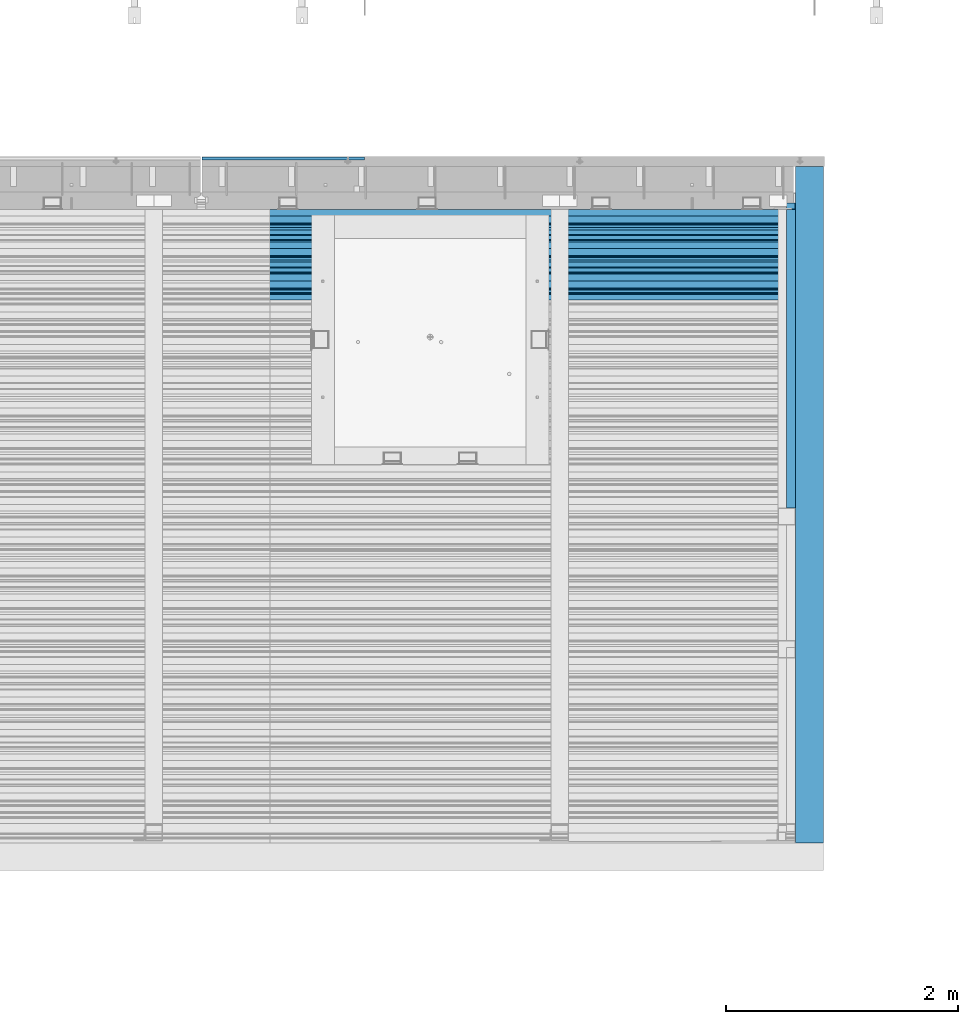
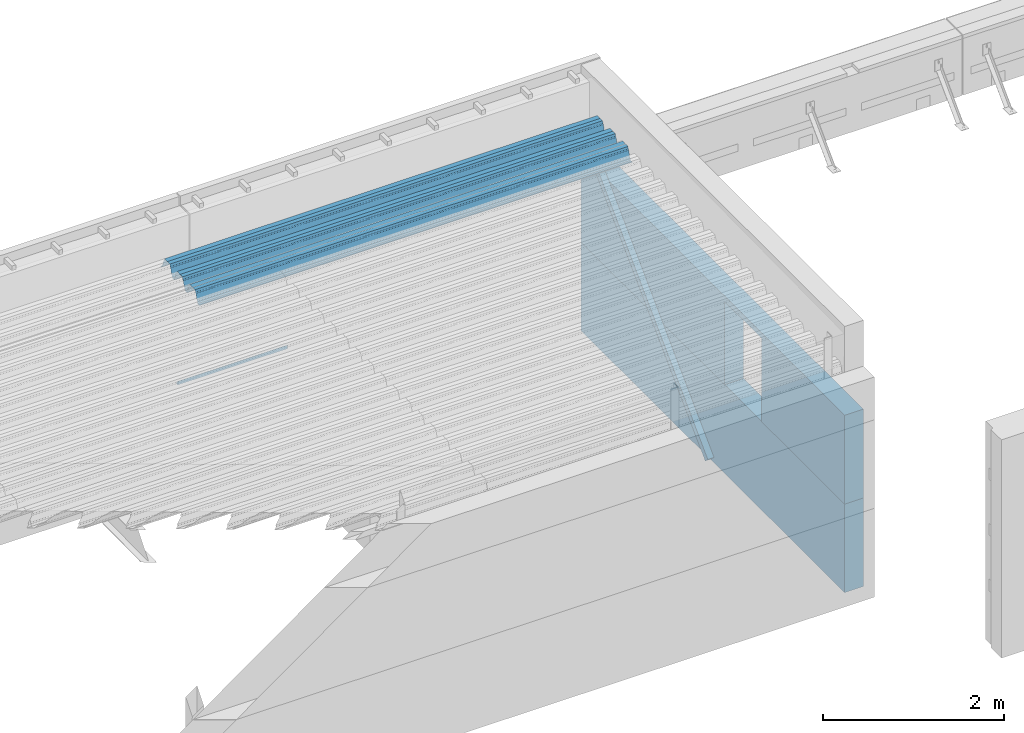
# One storey, part 42 of 153: 4 beams, 1 member, 5 elements without a shape of their own.
"""IFC2X3 building model written with IfcOpenShell, lengths in millimetres."""

from ifc_helpers import new_model, si_unit, frame, origin_with_axes, place, context, subcontext, project, spatial, faceted_brep, material, type_object, element, aggregate, save


model = new_model("IFC2X3")

# Units and contexts
model_context = context("Model", 3, precision=1e-05, world=origin_with_axes())
body_context = subcontext(model_context, "Body", "Model", "MODEL_VIEW")
ifc_project = project(units=[si_unit("LENGTHUNIT", "METRE", prefix="MILLI"), si_unit("AREAUNIT", "SQUARE_METRE"), si_unit("VOLUMEUNIT", "CUBIC_METRE"), si_unit("MASSUNIT", "GRAM", prefix="KILO"), si_unit("TIMEUNIT", "SECOND"), si_unit("PLANEANGLEUNIT", "RADIAN"), si_unit("SOLIDANGLEUNIT", "STERADIAN"), si_unit("THERMODYNAMICTEMPERATUREUNIT", "DEGREE_CELSIUS"), si_unit("LUMINOUSINTENSITYUNIT", "LUMEN")], contexts=[model_context])

# Site, building, storey
site_placement = place(None, origin_with_axes())
site = spatial("IfcSite", under=ifc_project, at=site_placement, CompositionType="ELEMENT")
building_placement = place(site_placement, origin_with_axes())
building = spatial("IfcBuilding", under=site, at=building_placement, CompositionType="ELEMENT")
storey_placement = place(building_placement, origin_with_axes())
storey = spatial("IfcBuildingStorey", under=building, at=storey_placement, Name="8", CompositionType="ELEMENT", Elevation=0.0)

# Assembly, member
assembly_1_placement = place(storey_placement, origin_with_axes())
assembly_1 = element("IfcElementAssembly", 1, at=assembly_1_placement, inside=storey, Name="Steel Assembly", AssemblyPlace="NOTDEFINED", PredefinedType="RIGID_FRAME")
ifc_material_1 = material(Name="STEEL/S355J2")
member_type = type_object("IfcMemberType", Name="80X80X4", PredefinedType="NOTDEFINED")
member_placement = place(assembly_1_placement, frame((21747.0, 17883.2842712475, 102801.715728753), z_axis=(0.0, -0.70710678118662, 0.707106781186475), x_axis=(0.0, 0.70710678118655, 0.707106781186545)))
member = element("IfcMember", 2, at=member_placement, type_object=member_type, material=ifc_material_1, ObjectType="80X80X4", context=body_context, shape_type="Brep", body=[
    faceted_brep([(0.0, 36.0, -36.0), (0.0, -36.0, -36.0), (3641.59992311073, -36.0, -35.9999999999854), (3641.59992311073, 36.0, -35.9999999999854), (0.0, -36.0, 36.0), (3641.59992311073, -36.0, 36.0), (0.0, 36.0, 36.0), (3641.59992311073, 36.0, 36.0), (0.0, 40.0, -40.0), (0.0, 40.0, 40.0), (3641.59992311073, 40.0, 40.0000000000146), (3641.59992311073, 40.0, -40.0), (0.0, -40.0, 40.0), (3641.59992311073, -40.0, 40.0000000000146), (0.0, -40.0, -40.0), (3641.59992311073, -40.0, -40.0)], [[[0, 1, 2, 3]], [[1, 4, 5, 2]], [[4, 6, 7, 5]], [[6, 0, 3, 7]], [[8, 9, 10, 11]], [[9, 12, 13, 10]], [[12, 14, 15, 13]], [[14, 8, 11, 15]], [[13, 15, 11, 10], [5, 7, 3, 2]], [[14, 12, 9, 8], [6, 4, 1, 0]]]),
])
aggregate(assembly_1, [member])

# Assembly, beam
assembly_2_placement = place(storey_placement, origin_with_axes())
assembly_2 = element("IfcElementAssembly", 3, at=assembly_2_placement, inside=storey, AssemblyPlace="NOTDEFINED", PredefinedType="REINFORCEMENT_UNIT")
ifc_material_2 = material(Name="TIMBER/T24")
beam_type_1 = type_object("IfcBeamType", PredefinedType="NOTDEFINED")
beam_1_placement = place(assembly_2_placement, frame((16667.5, 20867.5, 103805.0), z_axis=(0.0, 1.0, 0.0), x_axis=(1.0, 0.0, 0.0)))
beam_1 = element("IfcBeam", 4, at=beam_1_placement, type_object=beam_type_1, material=ifc_material_2, context=body_context, shape_type="Brep", body=[
    faceted_brep([(1400.0, -6.41739461570978e-09, 12.4999999936263), (1.45519152283669e-11, -3.63797880709171e-12, 12.4999999999964), (0.0, -25.0, -12.5), (1400.0, -25.0, -12.5), (0.0, 25.0, -12.5), (0.0, 25.0, 12.5), (1400.0, 25.0, 12.5), (1400.0, 25.0, -12.5)], [[[0, 1, 2, 3]], [[4, 5, 6, 7]], [[7, 6, 0, 3]], [[4, 7, 3, 2]], [[5, 4, 2, 1]], [[6, 5, 1, 0]]]),
])
aggregate(assembly_2, [beam_1])

assembly_3_placement = place(storey_placement, origin_with_axes())
assembly_3 = element("IfcElementAssembly", 5, at=assembly_3_placement, inside=storey, Name="Steel Assembly", AssemblyPlace="NOTDEFINED", PredefinedType="RIGID_FRAME")
beam_type_2 = type_object("IfcBeamType", Name="W", PredefinedType="NOTDEFINED")
beam_2_placement = place(assembly_3_placement, frame((21782.0, 20081.9521353322, 105808.609792946), z_axis=(0.0, -0.0124990270013869, 0.999921884110963), x_axis=(-1.0, 3.00000001838171e-08, 0.0)))
beam_2 = element("IfcBeam", 6, at=beam_2_placement, type_object=beam_type_2, material=ifc_material_1, ObjectType="W", context=body_context, shape_type="Brep", body=[
    faceted_brep([(0.0, -412.839996337891, -77.0100021362159), (0.0, -409.160003662109, -77.0100021362014), (5530.0, -409.160003662109, -77.0100021362014), (5530.0, -412.839996337891, -77.0100021362159), (0.0, -408.070007324222, -73.4800033569045), (5530.0, -408.070007324222, -73.4800033569045), (0.0, -400.339996337894, -48.0600013732619), (5530.0, -400.339996337894, -48.0600013732619), (0.0, -399.459991455082, -46.5600013732619), (5530.0, -399.459991455082, -46.5600013732619), (0.0, -390.329986572269, -36.5499992370314), (5530.0, -390.329986572269, -36.5499992370314), (0.0, -389.19000244141, -34.6300010680861), (5530.0, -389.19000244141, -34.6300010680861), (0.0, -367.820007324222, 35.3400001526024), (5530.0, -367.820007324222, 35.3400001526024), (0.0, -366.989990234379, 36.8499984741502), (5530.0, -366.989990234379, 36.8499984741502), (0.0, -357.809997558597, 46.8600006103807), (5530.0, -357.809997558597, 46.8600006103807), (0.0, -356.720001220707, 48.7700004577782), (5530.0, -356.720001220707, 48.7700004577782), (0.0, -349.309997558594, 73.1500015258935), (5530.0, -349.309997558594, 73.1500015258935), (0.0, -347.850006103516, 75.2300033569481), (5530.0, -347.850006103516, 75.2300033569481), (0.0, -345.470001220707, 76.010002136245), (5530.0, -345.470001220707, 76.010002136245), (0.0, -305.480010986332, 76.010002136245), (5530.0, -305.480010986332, 76.010002136245), (0.0, -304.279998779301, 75.8000030517578), (5530.0, -304.279998779301, 75.8000030517578), (0.0, -291.679992675785, 71.6999969482567), (5530.0, -291.679992675785, 71.6999969482567), (0.0, -290.179992675789, 71.2300033569481), (5530.0, -290.179992675789, 71.2300033569481), (0.0, -288.720001220707, 71.6999969482567), (5530.0, -288.720001220707, 71.6999969482567), (0.0, -276.119995117191, 75.8000030517869), (5530.0, -276.119995117191, 75.8000030517869), (0.0, -274.929992675785, 76.010002136245), (5530.0, -274.929992675785, 76.010002136245), (0.0, -234.94000244141, 76.010002136245), (5530.0, -234.94000244141, 76.010002136245), (0.0, -232.550003051758, 75.2300033569627), (5530.0, -232.550003051758, 75.2300033569627), (0.0, -231.100006103519, 73.1500015258935), (5530.0, -231.100006103519, 73.1500015258935), (0.0, -223.679992675785, 48.7700004577782), (5530.0, -223.679992675785, 48.7700004577782), (0.0, -222.589996337894, 46.8600006103661), (5530.0, -222.589996337894, 46.8600006103661), (0.0, -213.410003662113, 36.8499984741502), (5530.0, -213.410003662113, 36.8499984741502), (0.0, -212.529998779301, 35.3400001526024), (5530.0, -212.529998779301, 35.3400001526024), (0.0, -191.160003662109, -34.6300010681007), (5530.0, -191.160003662109, -34.6300010681007), (0.0, -190.070007324222, -36.5499992370605), (5530.0, -190.070007324222, -36.5499992370605), (0.0, -180.940002441406, -46.560001373291), (5530.0, -180.940002441406, -46.560001373291), (0.0, -180.059997558597, -48.0600013732619), (5530.0, -180.059997558597, -48.0600013732619), (0.0, -172.330001831055, -73.480003356919), (5530.0, -172.330001831055, -73.480003356919), (0.0, -171.240005493168, -77.0100021362159), (5530.0, -171.240005493168, -77.0100021362159), (0.0, -129.330001831062, -77.0100021362014), (5530.0, -129.330001831062, -77.0100021362014), (0.0, -128.300003051761, -73.480003356919), (5530.0, -128.300003051761, -73.480003356919), (0.0, -120.51999664307, -48.0600013732765), (5530.0, -120.51999664307, -48.0600013732765), (0.0, -119.629997253418, -46.5600013732765), (5530.0, -119.629997253418, -46.5600013732765), (0.0, -110.500000000004, -36.5499992370314), (5530.0, -110.500000000004, -36.5499992370314), (0.0, -109.419998168949, -34.6300010680861), (5530.0, -109.419998168949, -34.6300010680861), (0.0, -88.0500030517615, 35.3400001526024), (5530.0, -88.0500030517615, 35.3400001526024), (0.0, -87.160003662113, 36.8499984741356), (5530.0, -87.160003662113, 36.8499984741356), (0.0, -78.0400009155273, 46.8600006103807), (5530.0, -78.0400009155273, 46.8600006103807), (0.0, -76.8899993896557, 48.7700004577782), (5530.0, -76.8899993896557, 48.7700004577782), (0.0, -69.4800033569336, 73.1500015258935), (5530.0, -69.4800033569336, 73.1500015258935), (0.0, -68.0299987793042, 75.2300033569336), (5530.0, -68.0299987793042, 75.2300033569336), (0.0, -65.6399993896521, 76.010002136245), (5530.0, -65.6399993896521, 76.010002136245), (0.0, -25.6499996185375, 76.0100021362596), (5530.0, -25.6499996185375, 76.0100021362596), (0.0, -24.5100002288891, 75.8000030517724), (5530.0, -24.5100002288891, 75.8000030517724), (0.0, -11.8500003814697, 71.6999969482567), (5530.0, -11.8500003814697, 71.6999969482567), (0.0, -10.3999996185339, 71.2300033569481), (5530.0, -10.3999996185339, 71.2300033569481), (0.0, -8.89999961853391, 71.6999969482567), (5530.0, -8.89999961853391, 71.6999969482567), (0.0, 3.71000003814333, 75.8000030517724), (5530.0, 3.71000003814333, 75.8000030517724), (0.0, 4.90000009536379, 76.0100021362596), (5530.0, 4.90000009536379, 76.0100021362596), (0.0, 44.8899993896484, 76.010002136245), (5530.0, 44.8899993896484, 76.010002136245), (0.0, 47.2799987792932, 75.2300033569481), (5530.0, 47.2799987792932, 75.2300033569481), (0.0, 48.6800003051721, 73.1500015258935), (5530.0, 48.6800003051721, 73.1500015258935), (0.0, 56.1500015258753, 48.7700004577782), (5530.0, 56.1500015258753, 48.7700004577782), (0.0, 57.2400016784632, 46.8600006103807), (5530.0, 57.2400016784632, 46.8600006103807), (0.0, 66.3700027465784, 36.8499984741211), (5530.0, 66.3700027465784, 36.8499984741211), (0.0, 67.2499999999964, 35.3400001526024), (5530.0, 67.2499999999964, 35.3400001526024), (0.0, 88.6200027465748, -34.6300010681007), (5530.0, 88.6200027465748, -34.6300010681007), (0.0, 89.709999084469, -36.549999237046), (5530.0, 89.709999084469, -36.549999237046), (0.0, 98.8899993896412, -46.5600013732765), (5530.0, 98.8899993896412, -46.5600013732765), (0.0, 99.7699966430628, -48.0600013732765), (5530.0, 99.7699966430628, -48.0600013732765), (0.0, 107.499999999996, -73.4800033569336), (5530.0, 107.499999999996, -73.4800033569336), (0.0, 108.589996337887, -77.0100021362014), (5530.0, 108.589996337887, -77.0100021362014), (0.0, 112.269996643063, -77.0100021362159), (5530.0, 112.269996643063, -77.0100021362159), (0.0, 146.759994506836, -77.0100021362159), (5530.0, 146.759994506836, -77.0100021362159), (0.0, 150.440002441403, -77.0100021362159), (5530.0, 150.440002441403, -77.0100021362159), (0.0, 151.529998779297, -73.480003356919), (5530.0, 151.529998779297, -73.480003356919), (0.0, 159.30999755859, -48.0600013732765), (5530.0, 159.30999755859, -48.0600013732765), (0.0, 160.190002441406, -46.5600013732619), (5530.0, 160.190002441406, -46.5600013732619), (0.0, 169.320007324215, -36.549999237046), (5530.0, 169.320007324215, -36.549999237046), (0.0, 170.410003662106, -34.6300010680861), (5530.0, 170.410003662106, -34.6300010680861), (0.0, 191.779998779293, 35.3400001526024), (5530.0, 191.779998779293, 35.3400001526024), (0.0, 192.660003662109, 36.8499984741502), (5530.0, 192.660003662109, 36.8499984741502), (0.0, 201.789993286129, 46.8600006103661), (5530.0, 201.789993286129, 46.8600006103661), (0.0, 202.880004882809, 48.7700004577637), (5530.0, 202.880004882809, 48.7700004577637), (0.0, 210.350006103512, 73.150001525908), (5530.0, 210.350006103512, 73.150001525908), (0.0, 211.800003051754, 75.2300033569481), (5530.0, 211.800003051754, 75.2300033569481), (0.0, 214.190002441406, 76.010002136245), (5530.0, 214.190002441406, 76.010002136245), (0.0, 254.179992675778, 76.010002136245), (5530.0, 254.179992675778, 76.010002136245), (0.0, 255.320007324215, 75.8000030517869), (5530.0, 255.320007324215, 75.8000030517869), (0.0, 267.980010986324, 71.6999969482713), (5530.0, 267.980010986324, 71.6999969482713), (0.0, 269.429992675778, 71.2300033569481), (5530.0, 269.429992675778, 71.2300033569481), (0.0, 270.880004882809, 71.6999969482567), (5530.0, 270.880004882809, 71.6999969482567), (0.0, 283.540008544918, 75.8000030517869), (5530.0, 283.540008544918, 75.8000030517869), (0.0, 284.679992675778, 76.010002136245), (5530.0, 284.679992675778, 76.010002136245), (0.0, 324.670013427731, 76.010002136245), (5530.0, 324.670013427731, 76.010002136245), (0.0, 327.049987792969, 75.2300033569627), (5530.0, 327.049987792969, 75.2300033569627), (0.0, 328.510009765625, 73.1500015258789), (5530.0, 328.510009765625, 73.1500015258789), (0.0, 335.980010986324, 48.7700004577782), (5530.0, 335.980010986324, 48.7700004577782), (0.0, 337.05999755859, 46.8600006103661), (5530.0, 337.05999755859, 46.8600006103661), (0.0, 346.190002441399, 36.8499984741356), (5530.0, 346.190002441399, 36.8499984741356), (0.0, 347.079986572266, 35.3400001526024), (5530.0, 347.079986572266, 35.3400001526024), (0.0, 368.450012207028, -34.6300010680861), (5530.0, 368.450012207028, -34.6300010680861), (0.0, 369.529998779293, -36.5499992370314), (5530.0, 369.529998779293, -36.5499992370314), (0.0, 378.660003662106, -46.5600013732619), (5530.0, 378.660003662106, -46.5600013732619), (0.0, 379.540008544918, -48.0600013732619), (5530.0, 379.540008544918, -48.0600013732619), (0.0, 387.329986572262, -73.480003356919), (5530.0, 387.329986572262, -73.480003356919), (0.0, 388.410003662109, -77.0100021362159), (5530.0, 388.410003662109, -77.0100021362159), (0.0, 392.100006103512, -77.0100021362159), (5530.0, 392.100006103512, -77.0100021362159), (0.0, 426.589996337887, -77.0100021362159), (5530.0, 426.589996337887, -77.0100021362159), (0.0, 430.269989013668, -77.0100021362159), (5530.0, 430.269989013668, -77.0100021362159), (0.0, 431.359985351559, -73.4800033569045), (5530.0, 431.359985351559, -73.4800033569045), (0.0, 433.179992675778, -67.5699996948097), (5530.0, 433.179992675778, -67.5699996948097), (0.0, 432.220001220699, -67.2699966430373), (5530.0, 432.220001220699, -67.2699966430373), (0.0, 430.410003662106, -73.1800003051612), (5530.0, 430.410003662106, -73.1800003051612), (0.0, 429.529998779293, -76.0100021362159), (5530.0, 429.529998779293, -76.0100021362159), (0.0, 426.589996337891, -76.0100021362159), (5530.0, 426.589996337891, -76.0100021362159), (0.0, 392.100006103512, -76.0100021362159), (5530.0, 392.100006103512, -76.0100021362159), (0.0, 389.149993896481, -76.0100021362014), (5530.0, 389.149993896481, -76.0100021362014), (0.0, 388.279998779293, -73.1800003051467), (5530.0, 388.279998779293, -73.1800003051467), (0.0, 380.470001220699, -47.659999847383), (5530.0, 380.470001220699, -47.659999847383), (0.0, 379.470001220699, -45.9599990844436), (5530.0, 379.470001220699, -45.9599990844436), (0.0, 370.350006103512, -35.9599990844581), (5530.0, 370.350006103512, -35.9599990844581), (0.0, 369.369995117184, -34.2299995422218), (5530.0, 369.369995117184, -34.2299995422218), (0.0, 347.999999999996, 35.7500000000146), (5530.0, 347.999999999996, 35.7500000000146), (0.0, 346.999999999996, 37.4399986267235), (5530.0, 346.999999999996, 37.4399986267235), (0.0, 337.880004882809, 47.450000762954), (5530.0, 337.880004882809, 47.450000762954), (0.0, 336.899993896481, 49.1699981689453), (5530.0, 336.899993896481, 49.1699981689453), (0.0, 329.420013427731, 73.5999984741356), (5530.0, 329.420013427731, 73.5999984741356), (0.0, 327.679992675781, 76.0699996948533), (5530.0, 327.679992675781, 76.0699996948533), (0.0, 324.829986572262, 77.010002136245), (5530.0, 324.829986572262, 77.010002136245), (0.0, 284.589996337887, 77.010002136245), (5530.0, 284.589996337887, 77.010002136245), (0.0, 283.290008544922, 76.769996643081), (5530.0, 283.290008544922, 76.769996643081), (0.0, 270.570007324215, 72.6500015258935), (5530.0, 270.570007324215, 72.6500015258935), (0.0, 269.429992675781, 72.2799987793114), (5530.0, 269.429992675781, 72.2799987793114), (0.0, 268.279998779293, 72.650001525908), (5530.0, 268.279998779293, 72.650001525908), (0.0, 255.570007324219, 76.769996643081), (5530.0, 255.570007324219, 76.769996643081), (0.0, 254.270004272461, 77.0100021362596), (5530.0, 254.270004272461, 77.0100021362596), (0.0, 214.029998779293, 77.0100021362596), (5530.0, 214.029998779293, 77.0100021362596), (0.0, 211.179992675781, 76.0699996948388), (5530.0, 211.179992675781, 76.0699996948388), (0.0, 209.440002441403, 73.5999984741356), (5530.0, 209.440002441403, 73.5999984741356), (0.0, 201.960006713864, 49.1699981689599), (5530.0, 201.960006713864, 49.1699981689599), (0.0, 200.979995727532, 47.450000762954), (5530.0, 200.979995727532, 47.450000762954), (0.0, 191.850006103508, 37.4399986267235), (5530.0, 191.850006103508, 37.4399986267235), (0.0, 190.860000610352, 35.7500000000146), (5530.0, 190.860000610352, 35.7500000000146), (0.0, 169.49000549316, -34.2299995422218), (5530.0, 169.49000549316, -34.2299995422218), (0.0, 168.509994506832, -35.9599990844581), (5530.0, 168.509994506832, -35.9599990844581), (0.0, 159.380004882805, -45.9599990844436), (5530.0, 159.380004882805, -45.9599990844436), (0.0, 158.389999389645, -47.6599998473976), (5530.0, 158.389999389645, -47.6599998473976), (0.0, 150.580001831051, -73.1800003051612), (5530.0, 150.580001831051, -73.1800003051612), (0.0, 149.710006713864, -76.0100021362159), (5530.0, 149.710006713864, -76.0100021362159), (0.0, 146.759994506836, -76.0100021362159), (5530.0, 146.759994506836, -76.0100021362159), (0.0, 112.269996643063, -76.0100021362159), (5530.0, 112.269996643063, -76.0100021362159), (0.0, 109.319999694821, -76.0100021362159), (5530.0, 109.319999694821, -76.0100021362159), (0.0, 108.449996948239, -73.1900024413917), (5530.0, 108.449996948239, -73.1900024413917), (0.0, 100.690002441406, -47.659999847383), (5530.0, 100.690002441406, -47.659999847383), (0.0, 99.6999969482386, -45.9599990844581), (5530.0, 99.6999969482386, -45.9599990844581), (0.0, 90.5199966430664, -35.9599990844581), (5530.0, 90.5199966430664, -35.9599990844581), (0.0, 89.5400009155273, -34.2299995422218), (5530.0, 89.5400009155273, -34.2299995422218), (0.0, 68.1699981689417, 35.7500000000146), (5530.0, 68.1699981689417, 35.7500000000146), (0.0, 67.1699981689417, 37.4399986267235), (5530.0, 67.1699981689417, 37.4399986267235), (0.0, 58.0499992370569, 47.4500007629686), (5530.0, 58.0499992370569, 47.4500007629686), (0.0, 57.0699996948206, 49.1699981689599), (5530.0, 57.0699996948206, 49.1699981689599), (0.0, 49.5900001525843, 73.5899963379052), (5530.0, 49.5900001525843, 73.5899963379052), (0.0, 47.9099998474085, 76.0699996948388), (5530.0, 47.9099998474085, 76.0699996948388), (0.0, 45.0499992370569, 77.010002136245), (5530.0, 45.0499992370569, 77.010002136245), (0.0, 4.82000017165774, 77.010002136245), (5530.0, 4.82000017165774, 77.010002136245), (0.0, 3.47000002860659, 76.7699966430955), (5530.0, 3.47000002860659, 76.7699966430955), (0.0, -9.19999980926514, 72.6500015258935), (5530.0, -9.19999980926514, 72.6500015258935), (0.0, -10.3900003433264, 72.2799987792969), (5530.0, -10.3900003433264, 72.2799987792969), (0.0, -11.5399999618567, 72.6500015258935), (5530.0, -11.5399999618567, 72.6500015258935), (0.0, -24.2600002288855, 76.769996643081), (5530.0, -24.2600002288855, 76.769996643081), (0.0, -25.559999465946, 77.0100021362596), (5530.0, -25.559999465946, 77.0100021362596), (0.0, -65.8000030517615, 77.0100021362596), (5530.0, -65.8000030517615, 77.0100021362596), (0.0, -68.6500015258862, 76.0699996948533), (5530.0, -68.6500015258862, 76.0699996948533), (0.0, -70.3899993896521, 73.5999984741356), (5530.0, -70.3899993896521, 73.5999984741356), (0.0, -77.8199996948242, 49.1800003051903), (5530.0, -77.8199996948242, 49.1800003051903), (0.0, -78.8399963378943, 47.450000762954), (5530.0, -78.8399963378943, 47.450000762954), (0.0, -87.9700012207031, 37.4399986267235), (5530.0, -87.9700012207031, 37.4399986267235), (0.0, -88.9700012207068, 35.7500000000146), (5530.0, -88.9700012207068, 35.7500000000146), (0.0, -110.339996337894, -34.2299995422218), (5530.0, -110.339996337894, -34.2299995422218), (0.0, -111.319999694828, -35.9599990844581), (5530.0, -111.319999694828, -35.9599990844581), (0.0, -120.440002441406, -45.9599990844436), (5530.0, -120.440002441406, -45.9599990844436), (0.0, -121.44000244141, -47.6599998473976), (5530.0, -121.44000244141, -47.6599998473976), (0.0, -129.250000000004, -73.1900024413771), (5530.0, -129.250000000004, -73.1900024413771), (0.0, -130.080001831062, -76.0100021362159), (5530.0, -130.080001831062, -76.0100021362159), (0.0, -170.5, -76.0100021362014), (5530.0, -170.5, -76.0100021362014), (0.0, -171.380004882816, -73.1900024413917), (5530.0, -171.380004882816, -73.1900024413917), (0.0, -179.139999389652, -47.6599998473976), (5530.0, -179.139999389652, -47.6599998473976), (0.0, -180.130004882816, -45.9599990844581), (5530.0, -180.130004882816, -45.9599990844581), (0.0, -189.259994506836, -35.9599990844581), (5530.0, -189.259994506836, -35.9599990844581), (0.0, -190.240005493168, -34.2299995422218), (5530.0, -190.240005493168, -34.2299995422218), (0.0, -211.610000610355, 35.7500000000146), (5530.0, -211.610000610355, 35.7500000000146), (0.0, -212.600006103519, 37.4399986267381), (5530.0, -212.600006103519, 37.4399986267381), (0.0, -221.779998779301, 47.450000762954), (5530.0, -221.779998779301, 47.450000762954), (0.0, -222.75999450684, 49.1699981689599), (5530.0, -222.75999450684, 49.1699981689599), (0.0, -230.190002441406, 73.5999984741356), (5530.0, -230.190002441406, 73.5999984741356), (0.0, -231.919998168945, 76.0699996948388), (5530.0, -231.919998168945, 76.0699996948388), (0.0, -234.779998779301, 77.010002136245), (5530.0, -234.779998779301, 77.010002136245), (0.0, -275.010009765629, 77.010002136245), (5530.0, -275.010009765629, 77.010002136245), (0.0, -276.359985351563, 76.769996643081), (5530.0, -276.359985351563, 76.769996643081), (0.0, -289.029998779297, 72.6500015258789), (5530.0, -289.029998779297, 72.6500015258789), (0.0, -290.179992675785, 72.2799987793114), (5530.0, -290.179992675785, 72.2799987793114), (0.0, -291.380004882816, 72.650001525908), (5530.0, -291.380004882816, 72.650001525908), (0.0, -304.040008544926, 76.769996643081), (5530.0, -304.040008544926, 76.769996643081), (0.0, -305.390014648441, 77.010002136245), (5530.0, -305.390014648441, 77.010002136245), (0.0, -345.63000488282, 77.0100021362596), (5530.0, -345.63000488282, 77.0100021362596), (0.0, -348.480010986332, 76.0699996948388), (5530.0, -348.480010986332, 76.0699996948388), (0.0, -350.220001220707, 73.5999984741356), (5530.0, -350.220001220707, 73.5999984741356), (0.0, -357.649993896492, 49.1699981689599), (5530.0, -357.649993896492, 49.1699981689599), (0.0, -358.63000488282, 47.450000762954), (5530.0, -358.63000488282, 47.450000762954), (0.0, -367.809997558594, 37.4300003051903), (5530.0, -367.809997558594, 37.4300003051903), (0.0, -368.750000000004, 35.7299995422654), (5530.0, -368.750000000004, 35.7299995422654), (0.0, -390.109985351566, -34.2200012207031), (5530.0, -390.109985351566, -34.2200012207031), (0.0, -391.140014648441, -35.9500007629249), (5530.0, -391.140014648441, -35.9500007629249), (0.0, -400.269989013676, -45.9599990844436), (5530.0, -400.269989013676, -45.9599990844436), (0.0, -401.269989013672, -47.6599998473976), (5530.0, -401.269989013672, -47.6599998473976), (0.0, -409.029998779297, -73.1900024413917), (5530.0, -409.029998779297, -73.1900024413917), (0.0, -409.899993896488, -76.0100021362159), (5530.0, -409.899993896488, -76.0100021362159), (0.0, -412.839996337891, -76.0100021362159), (5530.0, -412.839996337891, -76.0100021362159), (0.0, -433.179992675785, -76.0100021362159), (5530.0, -433.179992675785, -76.0100021362159), (0.0, -433.179992675785, -77.0100021362159), (5530.0, -433.179992675785, -77.0100021362159)], [[[0, 1, 2, 3]], [[1, 4, 5, 2]], [[4, 6, 7, 5]], [[6, 8, 9, 7]], [[8, 10, 11, 9]], [[10, 12, 13, 11]], [[12, 14, 15, 13]], [[14, 16, 17, 15]], [[16, 18, 19, 17]], [[18, 20, 21, 19]], [[20, 22, 23, 21]], [[22, 24, 25, 23]], [[24, 26, 27, 25]], [[26, 28, 29, 27]], [[28, 30, 31, 29]], [[30, 32, 33, 31]], [[32, 34, 35, 33]], [[34, 36, 37, 35]], [[36, 38, 39, 37]], [[38, 40, 41, 39]], [[40, 42, 43, 41]], [[42, 44, 45, 43]], [[44, 46, 47, 45]], [[46, 48, 49, 47]], [[48, 50, 51, 49]], [[50, 52, 53, 51]], [[52, 54, 55, 53]], [[54, 56, 57, 55]], [[56, 58, 59, 57]], [[58, 60, 61, 59]], [[60, 62, 63, 61]], [[62, 64, 65, 63]], [[64, 66, 67, 65]], [[66, 68, 69, 67]], [[68, 70, 71, 69]], [[70, 72, 73, 71]], [[72, 74, 75, 73]], [[74, 76, 77, 75]], [[76, 78, 79, 77]], [[78, 80, 81, 79]], [[80, 82, 83, 81]], [[82, 84, 85, 83]], [[84, 86, 87, 85]], [[86, 88, 89, 87]], [[88, 90, 91, 89]], [[90, 92, 93, 91]], [[92, 94, 95, 93]], [[94, 96, 97, 95]], [[96, 98, 99, 97]], [[98, 100, 101, 99]], [[100, 102, 103, 101]], [[102, 104, 105, 103]], [[104, 106, 107, 105]], [[106, 108, 109, 107]], [[108, 110, 111, 109]], [[110, 112, 113, 111]], [[112, 114, 115, 113]], [[114, 116, 117, 115]], [[116, 118, 119, 117]], [[118, 120, 121, 119]], [[120, 122, 123, 121]], [[122, 124, 125, 123]], [[124, 126, 127, 125]], [[126, 128, 129, 127]], [[128, 130, 131, 129]], [[130, 132, 133, 131]], [[132, 134, 135, 133]], [[134, 136, 137, 135]], [[136, 138, 139, 137]], [[138, 140, 141, 139]], [[140, 142, 143, 141]], [[142, 144, 145, 143]], [[144, 146, 147, 145]], [[146, 148, 149, 147]], [[148, 150, 151, 149]], [[150, 152, 153, 151]], [[152, 154, 155, 153]], [[154, 156, 157, 155]], [[156, 158, 159, 157]], [[158, 160, 161, 159]], [[160, 162, 163, 161]], [[162, 164, 165, 163]], [[164, 166, 167, 165]], [[166, 168, 169, 167]], [[168, 170, 171, 169]], [[170, 172, 173, 171]], [[172, 174, 175, 173]], [[174, 176, 177, 175]], [[176, 178, 179, 177]], [[178, 180, 181, 179]], [[180, 182, 183, 181]], [[182, 184, 185, 183]], [[184, 186, 187, 185]], [[186, 188, 189, 187]], [[188, 190, 191, 189]], [[190, 192, 193, 191]], [[192, 194, 195, 193]], [[194, 196, 197, 195]], [[196, 198, 199, 197]], [[198, 200, 201, 199]], [[200, 202, 203, 201]], [[202, 204, 205, 203]], [[204, 206, 207, 205]], [[206, 208, 209, 207]], [[208, 210, 211, 209]], [[210, 212, 213, 211]], [[212, 214, 215, 213]], [[214, 216, 217, 215]], [[216, 218, 219, 217]], [[218, 220, 221, 219]], [[220, 222, 223, 221]], [[222, 224, 225, 223]], [[224, 226, 227, 225]], [[226, 228, 229, 227]], [[228, 230, 231, 229]], [[230, 232, 233, 231]], [[232, 234, 235, 233]], [[234, 236, 237, 235]], [[236, 238, 239, 237]], [[238, 240, 241, 239]], [[240, 242, 243, 241]], [[242, 244, 245, 243]], [[244, 246, 247, 245]], [[246, 248, 249, 247]], [[248, 250, 251, 249]], [[250, 252, 253, 251]], [[252, 254, 255, 253]], [[254, 256, 257, 255]], [[256, 258, 259, 257]], [[258, 260, 261, 259]], [[260, 262, 263, 261]], [[262, 264, 265, 263]], [[264, 266, 267, 265]], [[266, 268, 269, 267]], [[268, 270, 271, 269]], [[270, 272, 273, 271]], [[272, 274, 275, 273]], [[274, 276, 277, 275]], [[276, 278, 279, 277]], [[278, 280, 281, 279]], [[280, 282, 283, 281]], [[282, 284, 285, 283]], [[284, 286, 287, 285]], [[286, 288, 289, 287]], [[288, 290, 291, 289]], [[290, 292, 293, 291]], [[292, 294, 295, 293]], [[294, 296, 297, 295]], [[296, 298, 299, 297]], [[298, 300, 301, 299]], [[300, 302, 303, 301]], [[302, 304, 305, 303]], [[304, 306, 307, 305]], [[306, 308, 309, 307]], [[308, 310, 311, 309]], [[310, 312, 313, 311]], [[312, 314, 315, 313]], [[314, 316, 317, 315]], [[316, 318, 319, 317]], [[318, 320, 321, 319]], [[320, 322, 323, 321]], [[322, 324, 325, 323]], [[324, 326, 327, 325]], [[326, 328, 329, 327]], [[328, 330, 331, 329]], [[330, 332, 333, 331]], [[332, 334, 335, 333]], [[334, 336, 337, 335]], [[336, 338, 339, 337]], [[338, 340, 341, 339]], [[340, 342, 343, 341]], [[342, 344, 345, 343]], [[344, 346, 347, 345]], [[346, 348, 349, 347]], [[348, 350, 351, 349]], [[350, 352, 353, 351]], [[352, 354, 355, 353]], [[354, 356, 357, 355]], [[356, 358, 359, 357]], [[358, 360, 361, 359]], [[360, 362, 363, 361]], [[362, 364, 365, 363]], [[364, 366, 367, 365]], [[366, 368, 369, 367]], [[368, 370, 371, 369]], [[370, 372, 373, 371]], [[372, 374, 375, 373]], [[374, 376, 377, 375]], [[376, 378, 379, 377]], [[378, 380, 381, 379]], [[380, 382, 383, 381]], [[382, 384, 385, 383]], [[384, 386, 387, 385]], [[386, 388, 389, 387]], [[388, 390, 391, 389]], [[390, 392, 393, 391]], [[392, 394, 395, 393]], [[394, 396, 397, 395]], [[396, 398, 399, 397]], [[398, 400, 401, 399]], [[400, 402, 403, 401]], [[402, 404, 405, 403]], [[404, 406, 407, 405]], [[406, 408, 409, 407]], [[408, 410, 411, 409]], [[410, 412, 413, 411]], [[412, 414, 415, 413]], [[414, 416, 417, 415]], [[416, 418, 419, 417]], [[418, 420, 421, 419]], [[420, 422, 423, 421]], [[422, 424, 425, 423]], [[424, 426, 427, 425]], [[426, 428, 429, 427]], [[428, 430, 431, 429]], [[430, 0, 3, 431]], [[5, 7, 9, 11, 13, 15, 17, 19, 21, 23, 25, 27, 29, 31, 33, 35, 37, 39, 41, 43, 45, 47, 49, 51, 53, 55, 57, 59, 61, 63, 65, 67, 69, 71, 73, 75, 77, 79, 81, 83, 85, 87, 89, 91, 93, 95, 97, 99, 101, 103, 105, 107, 109, 111, 113, 115, 117, 119, 121, 123, 125, 127, 129, 131, 133, 135, 137, 139, 141, 143, 145, 147, 149, 151, 153, 155, 157, 159, 161, 163, 165, 167, 169, 171, 173, 175, 177, 179, 181, 183, 185, 187, 189, 191, 193, 195, 197, 199, 201, 203, 205, 207, 209, 211, 213, 215, 217, 219, 221, 223, 225, 227, 229, 231, 233, 235, 237, 239, 241, 243, 245, 247, 249, 251, 253, 255, 257, 259, 261, 263, 265, 267, 269, 271, 273, 275, 277, 279, 281, 283, 285, 287, 289, 291, 293, 295, 297, 299, 301, 303, 305, 307, 309, 311, 313, 315, 317, 319, 321, 323, 325, 327, 329, 331, 333, 335, 337, 339, 341, 343, 345, 347, 349, 351, 353, 355, 357, 359, 361, 363, 365, 367, 369, 371, 373, 375, 377, 379, 381, 383, 385, 387, 389, 391, 393, 395, 397, 399, 401, 403, 405, 407, 409, 411, 413, 415, 417, 419, 421, 423, 425, 427, 429, 431, 3, 2]], [[430, 428, 426, 424, 422, 420, 418, 416, 414, 412, 410, 408, 406, 404, 402, 400, 398, 396, 394, 392, 390, 388, 386, 384, 382, 380, 378, 376, 374, 372, 370, 368, 366, 364, 362, 360, 358, 356, 354, 352, 350, 348, 346, 344, 342, 340, 338, 336, 334, 332, 330, 328, 326, 324, 322, 320, 318, 316, 314, 312, 310, 308, 306, 304, 302, 300, 298, 296, 294, 292, 290, 288, 286, 284, 282, 280, 278, 276, 274, 272, 270, 268, 266, 264, 262, 260, 258, 256, 254, 252, 250, 248, 246, 244, 242, 240, 238, 236, 234, 232, 230, 228, 226, 224, 222, 220, 218, 216, 214, 212, 210, 208, 206, 204, 202, 200, 198, 196, 194, 192, 190, 188, 186, 184, 182, 180, 178, 176, 174, 172, 170, 168, 166, 164, 162, 160, 158, 156, 154, 152, 150, 148, 146, 144, 142, 140, 138, 136, 134, 132, 130, 128, 126, 124, 122, 120, 118, 116, 114, 112, 110, 108, 106, 104, 102, 100, 98, 96, 94, 92, 90, 88, 86, 84, 82, 80, 78, 76, 74, 72, 70, 68, 66, 64, 62, 60, 58, 56, 54, 52, 50, 48, 46, 44, 42, 40, 38, 36, 34, 32, 30, 28, 26, 24, 22, 20, 18, 16, 14, 12, 10, 8, 6, 4, 1, 0]]]),
])
aggregate(assembly_3, [beam_2])

assembly_4_placement = place(storey_placement, origin_with_axes())
assembly_4 = element("IfcElementAssembly", 7, at=assembly_4_placement, inside=storey, Name="Steel Assembly", AssemblyPlace="NOTDEFINED", PredefinedType="NOTDEFINED")
ifc_material_3 = material()
beam_type_3 = type_object("IfcBeamType", PredefinedType="NOTDEFINED")
beam_3_placement = place(assembly_4_placement, frame((21907.0013586809, 14965.0025069363, 104550.0), z_axis=(0.0, 0.0, 1.0), x_axis=(0.0, 1.0, 0.0)))
beam_3 = element("IfcBeam", 8, at=beam_3_placement, type_object=beam_type_3, material=ifc_material_3, Name="SW", context=body_context, shape_type="Brep", body=[
    faceted_brep([(1834.99749306366, -120.0, -600.0), (1834.99749306366, 120.0, -600.0), (1834.99749306366, 120.0, 524.421424147789), (1834.99749306366, -120.0, 524.421424147789), (2654.99749306366, -120.0, 524.421424147789), (2654.99749306366, 120.0, 524.421424147789), (2654.99749306366, 120.0, -600.0), (2654.99749306366, -120.0, -600.0), (0.0, -120.0, -600.0), (0.0, -120.0, 600.0), (0.0, 120.0, 600.0), (0.0, 120.0, -600.0), (5834.99749306367, -120.0, 600.0), (5834.99749306367, 120.0, 600.0), (5834.99749306367, -120.0, -600.0), (5834.99749306367, 120.0, -600.0)], [[[0, 1, 2, 3]], [[4, 5, 6, 7]], [[3, 2, 5, 4]], [[8, 9, 10, 11]], [[10, 9, 12, 13]], [[12, 14, 15, 13]], [[15, 14, 7, 6]], [[1, 11, 10, 13, 15, 6, 5, 2]], [[8, 11, 1, 0]], [[14, 12, 9, 8, 0, 3, 4, 7]]]),
])
aggregate(assembly_4, [beam_3])

assembly_5_placement = place(storey_placement, origin_with_axes())
assembly_5 = element("IfcElementAssembly", 9, at=assembly_5_placement, inside=storey, Name="Steel Assembly", AssemblyPlace="NOTDEFINED", PredefinedType="NOTDEFINED")
beam_4_placement = place(assembly_5_placement, frame((21907.0013586809, 14965.0025069363, 103355.0), z_axis=(0.0, 0.0, 1.0), x_axis=(0.0, 1.0, 0.0)))
beam_4 = element("IfcBeam", 10, at=beam_4_placement, type_object=beam_type_3, material=ifc_material_3, Name="SW", context=body_context, shape_type="Brep", body=[
    faceted_brep([(0.0, 120.0, -600.0), (0.0, 120.0, 600.0), (5834.99749306367, 120.0, 600.0), (5834.99749306367, 120.0, -600.0), (0.0, -120.0, 600.0), (5834.99749306367, -120.0, 600.0), (0.0, -120.0, -600.0), (5834.99749306367, -120.0, -600.0)], [[[0, 1, 2, 3]], [[1, 4, 5, 2]], [[4, 6, 7, 5]], [[6, 0, 3, 7]], [[5, 7, 3, 2]], [[6, 4, 1, 0]]]),
])
aggregate(assembly_5, [beam_4])

save(model, "model.ifc")
